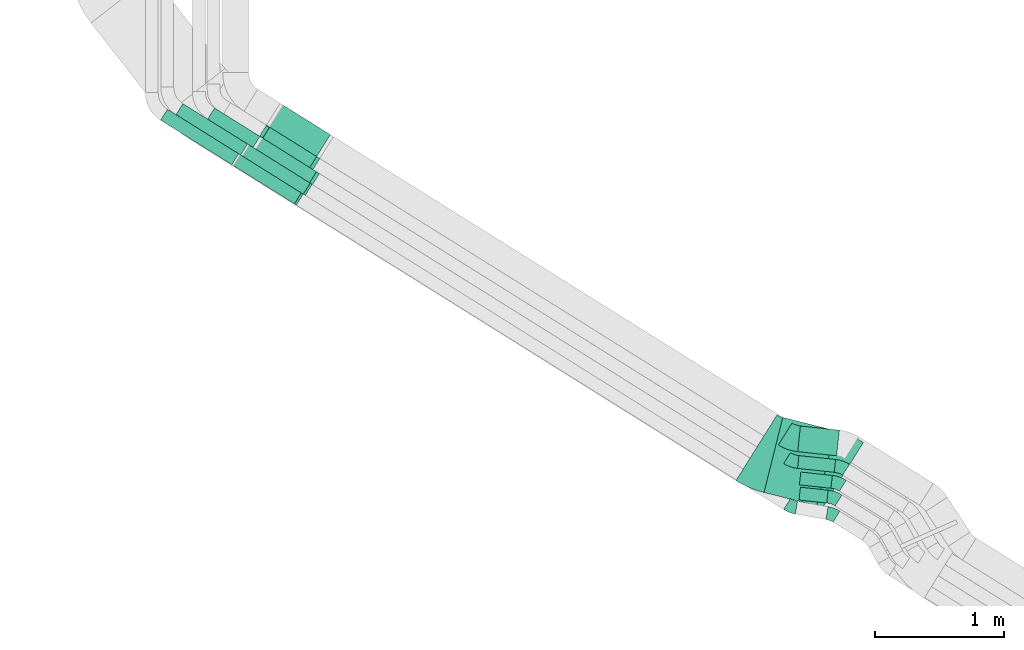
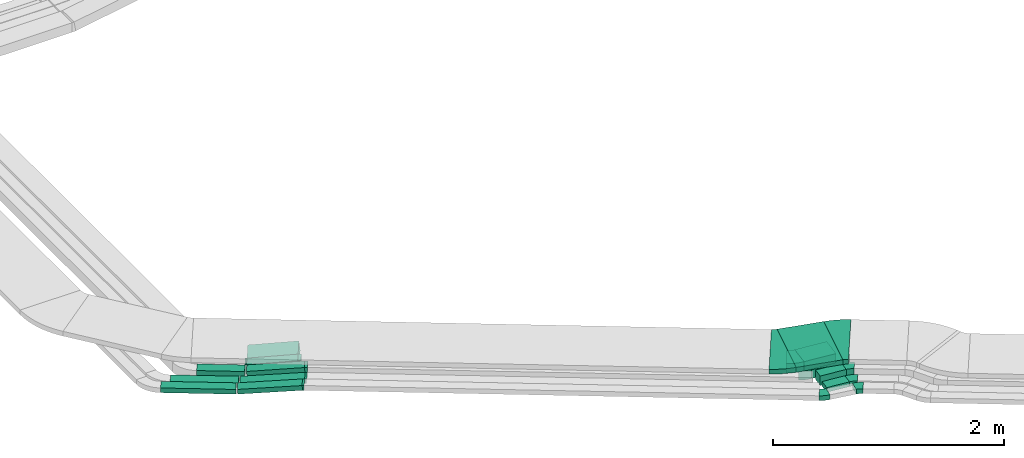
# One storey, part 8 of 38: 14 flow fittings, 13 flow segments.
"""IFC2X3 building model written with IfcOpenShell, lengths in millimetres."""

from ifc_helpers import new_model, entity, si_unit, converted_unit, derived_unit, direction, frame, frame_2d, origin, origin_2d_with_axis, place, context, subcontext, project, spatial, polyline, circle_curve, parameter, trimmed, segment, composite_curve, rectangle, outline, extrude, faceted_brep, source, transform, mapped, material, type_object, type_shapes, element, save


model = new_model("IFC2X3")

# Units and contexts
model_context = context("Model", 3, precision=0.01, world=origin(), true_north=direction((6.12303176911189e-17, 1.0)))
body_context = subcontext(model_context, "Body", "Model", "MODEL_VIEW")
ifc_project = project(units=[si_unit("LENGTHUNIT", "METRE", prefix="MILLI"), si_unit("AREAUNIT", "SQUARE_METRE"), si_unit("VOLUMEUNIT", "CUBIC_METRE"), converted_unit("PLANEANGLEUNIT", "DEGREE", entity("IfcRatioMeasure", 0.0174532925199433), si_unit("PLANEANGLEUNIT", "RADIAN"), dimensions=[0, 0, 0, 0, 0, 0, 0]), si_unit("MASSUNIT", "GRAM", prefix="KILO"), derived_unit("MASSDENSITYUNIT", [(si_unit("MASSUNIT", "GRAM", prefix="KILO"), 1), (si_unit("LENGTHUNIT", "METRE"), -3)]), derived_unit("MOMENTOFINERTIAUNIT", [(si_unit("LENGTHUNIT", "METRE"), 4)]), si_unit("TIMEUNIT", "SECOND"), si_unit("FREQUENCYUNIT", "HERTZ"), si_unit("THERMODYNAMICTEMPERATUREUNIT", "DEGREE_CELSIUS"), derived_unit("THERMALTRANSMITTANCEUNIT", [(si_unit("MASSUNIT", "GRAM", prefix="KILO"), 1), (si_unit("THERMODYNAMICTEMPERATUREUNIT", "KELVIN"), -1), (si_unit("TIMEUNIT", "SECOND"), -3)]), derived_unit("VOLUMETRICFLOWRATEUNIT", [(si_unit("LENGTHUNIT", "METRE"), 3), (si_unit("TIMEUNIT", "SECOND"), -1)]), derived_unit("MASSFLOWRATEUNIT", [(si_unit("MASSUNIT", "GRAM", prefix="KILO"), 1), (si_unit("TIMEUNIT", "SECOND"), -1)]), derived_unit("ROTATIONALFREQUENCYUNIT", [(si_unit("TIMEUNIT", "SECOND"), -1)]), si_unit("ELECTRICCURRENTUNIT", "AMPERE"), si_unit("ELECTRICVOLTAGEUNIT", "VOLT"), si_unit("POWERUNIT", "WATT"), si_unit("FORCEUNIT", "NEWTON", prefix="KILO"), si_unit("ILLUMINANCEUNIT", "LUX"), si_unit("LUMINOUSFLUXUNIT", "LUMEN"), si_unit("LUMINOUSINTENSITYUNIT", "CANDELA"), derived_unit("USERDEFINED", [(si_unit("MASSUNIT", "GRAM", prefix="KILO"), -1), (si_unit("LENGTHUNIT", "METRE"), -2), (si_unit("TIMEUNIT", "SECOND"), 3), (si_unit("LUMINOUSFLUXUNIT", "LUMEN"), 1)]), derived_unit("LINEARVELOCITYUNIT", [(si_unit("LENGTHUNIT", "METRE"), 1), (si_unit("TIMEUNIT", "SECOND"), -1)]), si_unit("PRESSUREUNIT", "PASCAL"), derived_unit("USERDEFINED", [(si_unit("LENGTHUNIT", "METRE"), -2), (si_unit("MASSUNIT", "GRAM", prefix="KILO"), 1), (si_unit("TIMEUNIT", "SECOND"), -2)]), derived_unit("LINEARFORCEUNIT", [(si_unit("MASSUNIT", "GRAM", prefix="KILO"), 1), (si_unit("LENGTHUNIT", "METRE"), 1), (si_unit("TIMEUNIT", "SECOND"), -2), (si_unit("LENGTHUNIT", "METRE"), -1)]), derived_unit("PLANARFORCEUNIT", [(si_unit("MASSUNIT", "GRAM", prefix="KILO"), 1), (si_unit("LENGTHUNIT", "METRE"), 1), (si_unit("TIMEUNIT", "SECOND"), -2), (si_unit("LENGTHUNIT", "METRE"), -2)])], contexts=[model_context])

# Site, building, storey
site_placement = place(None, frame((0.0, -0.00077364408347762, 0.0)))
site = spatial("IfcSite", under=ifc_project, at=site_placement, CompositionType="ELEMENT")
building_placement = place(site_placement, origin())
building = spatial("IfcBuilding", under=site, at=building_placement, CompositionType="ELEMENT")
storey_placement = place(building_placement, frame((0.0, 0.0, 4200.0)))
storey = spatial("IfcBuildingStorey", under=building, at=storey_placement, CompositionType="ELEMENT", Elevation=4200.0)

# Flow segments
cable_carrier_segment_type = type_object("IfcCableCarrierSegmentType", PredefinedType="CABLETRAYSEGMENT")
flow_segment_1_placement = place(storey_placement, frame((11021.9593826731, 6012.63176187368, 2780.0)))
element("IfcFlowSegment", 1, at=flow_segment_1_placement, inside=storey, type_object=cable_carrier_segment_type, context=body_context, shape_type="SweptSolid", body=[
    extrude(rectangle(XDim=590.779348946736, YDim=99.9999999999992, at=frame_2d((2.8421709430404e-13, -4.58300064565265e-13), x_axis=(1.0, 0.0))), frame((277.000614273059, 198.935083766848, 0.0), z_axis=(0.0, 0.0, 1.0), x_axis=(-0.848048096156395, 0.529919264233255, 0.0)), (0.0, 0.0, 1.0), 49.9999999999995),
])
flow_segment_2_placement = place(storey_placement, frame((10901.9593826731, 5937.63443186581, 2780.0)))
element("IfcFlowSegment", 2, at=flow_segment_2_placement, inside=storey, type_object=cable_carrier_segment_type, context=body_context, shape_type="SweptSolid", body=[
    extrude(rectangle(XDim=650.976943556377, YDim=99.9999999999992, at=frame_2d((-9.09494701772928e-13, -5.75539615965681e-13), x_axis=(1.0, 0.0))), frame((302.525842024012, 214.885016288922, 0.0), z_axis=(0.0, 0.0, 1.0), x_axis=(-0.848048096156398, 0.529919264233251, 0.0)), (0.0, 0.0, 1.0), 49.9999999999994),
])
flow_segment_3_placement = place(storey_placement, frame((15850.3279438837, 3315.85670143995, 2836.0)))
element("IfcFlowSegment", 3, at=flow_segment_3_placement, inside=storey, type_object=cable_carrier_segment_type, context=body_context, shape_type="SweptSolid", body=[
    extrude(rectangle(XDim=215.79362758406, YDim=99.9999999999994, at=frame_2d((1.03739239420975e-12, 3.90798504668055e-13), x_axis=(1.0, 0.0))), frame((112.591841789923, 61.1631080008714, 0.0), z_axis=(0.0, 0.0, 1.0), x_axis=(0.994358083083249, -0.106075457137867, 0.0)), (0.0, 0.0, 1.0), 49.9999999999994),
])
flow_segment_4_placement = place(storey_placement, frame((15852.9769620109, 3430.11873830787, 2836.0)))
element("IfcFlowSegment", 4, at=flow_segment_4_placement, inside=storey, type_object=cable_carrier_segment_type, context=body_context, shape_type="SweptSolid", body=[
    extrude(rectangle(XDim=245.980376559461, YDim=99.9999999999996, at=frame_2d((-3.5527136788005e-14, 2.66453525910038e-13), x_axis=(1.0, 0.0))), frame((127.60006071277, 62.7641445993965, 0.0), z_axis=(0.0, 0.0, 1.0), x_axis=(0.994358083083258, -0.106075457137776, 0.0)), (0.0, 0.0, 1.0), 99.9999999999989),
])
flow_segment_5_placement = place(storey_placement, frame((15838.5294447758, 3553.72125251607, 2836.0)))
element("IfcFlowSegment", 5, at=flow_segment_5_placement, inside=storey, type_object=cable_carrier_segment_type, context=body_context, shape_type="SweptSolid", body=[
    extrude(rectangle(XDim=285.980376559459, YDim=99.9999999999996, at=origin_2d_with_axis()), frame((147.487222374434, 64.8856537421533, 0.0), z_axis=(0.0, 0.0, 1.0), x_axis=(0.994358083083257, -0.106075457137787, 0.0)), (0.0, 0.0, 1.0), 99.9999999999989),
])
flow_segment_6_placement = place(storey_placement, frame((15839.5849562289, 3681.4986497442, 2836.0)))
element("IfcFlowSegment", 6, at=flow_segment_6_placement, inside=storey, type_object=cable_carrier_segment_type, context=body_context, shape_type="SweptSolid", body=[
    extrude(rectangle(XDim=303.568110682782, YDim=200.0, at=frame_2d((2.17426077142591e-12, -3.5527136788005e-14), x_axis=(1.0, 0.0))), frame((161.535248025646, 115.536371364891, 0.0), z_axis=(0.0, 0.0, 1.0), x_axis=(0.994358083083256, -0.106075457137793, 0.0)), (0.0, 0.0, 1.0), 99.9999999999989),
])
flow_segment_7_placement = place(storey_placement, frame((15578.6070161036, 3295.27526726807, 3108.85255784634)))
element("IfcFlowSegment", 7, at=flow_segment_7_placement, inside=storey, type_object=cable_carrier_segment_type, context=body_context, shape_type="SweptSolid", body=[
    extrude(rectangle(XDim=419.986776604596, YDim=600.000000000001, at=frame_2d((-1.03739239420975e-12, -2.55795384873636e-13), x_axis=(1.0, 0.0))), frame((276.332255895841, 341.89071644429, 0.0), z_axis=(0.0, 0.0, 1.0), x_axis=(0.970295726275994, -0.241921895599679, 0.0)), (0.0, 0.0, 1.0), 49.9999999999995),
])
flow_segment_8_placement = place(storey_placement, frame((11464.9459833345, 5631.65560913535, 2780.8615018426)))
element("IfcFlowSegment", 8, at=flow_segment_8_placement, inside=storey, type_object=cable_carrier_segment_type, context=body_context, shape_type="SweptSolid", body=[
    extrude(rectangle(XDim=50.0000000000007, YDim=100.0, at=frame_2d((0.0, 0.0), x_axis=(0.0, 1.0))), frame((28.5512409538923, 340.269098140738, 24.8822518695974), z_axis=(0.844053853043885, -0.527423384128046, 0.0969415650621141), x_axis=(0.529919264233164, 0.848048096156452, 0.0)), (0.0, 0.0, 1.0), 562.323215441914),
])
flow_segment_9_placement = place(storey_placement, frame((11533.8955278326, 5706.6529391432, 2780.8615018426)))
element("IfcFlowSegment", 9, at=flow_segment_9_placement, inside=storey, type_object=cable_carrier_segment_type, context=body_context, shape_type="SweptSolid", body=[
    extrude(rectangle(XDim=50.0000000000008, YDim=99.9999999999974, at=origin_2d_with_axis()), frame((28.5512409538923, 340.269098140755, 24.8822518695974), z_axis=(0.844053853043877, -0.527423384128054, 0.0969415650621368), x_axis=(-0.0822111096893616, 0.0513712028313554, 0.995290074783881)), (0.0, 0.0, 1.0), 562.323215441913),
])
flow_segment_10_placement = place(storey_placement, frame((11632.318333467, 5792.32698271948, 2781.41755828794)))
element("IfcFlowSegment", 10, at=flow_segment_10_placement, inside=storey, type_object=cable_carrier_segment_type, context=body_context, shape_type="SweptSolid", body=[
    extrude(rectangle(XDim=100.0, YDim=100.000000000001, at=origin_2d_with_axis()), frame((31.0187386409068, 310.671196419434, 49.7147605235467), z_axis=(0.843210160257302, -0.526896186363397, 0.106663182188436), x_axis=(-0.0904555085848854, 0.0565228750260753, 0.994295210470933)), (0.0, 0.0, 1.0), 503.785479436427),
])
flow_segment_11_placement = place(storey_placement, frame((11266.9593826731, 6071.81475346182, 2780.0)))
element("IfcFlowSegment", 11, at=flow_segment_11_placement, inside=storey, type_object=cable_carrier_segment_type, context=body_context, shape_type="SweptSolid", body=[
    extrude(rectangle(XDim=414.985433178406, YDim=99.9999999999999, at=frame_2d((-9.2370555648813e-13, -5.6843418860808e-13), x_axis=(1.0, 0.0))), frame((202.459766481463, 152.356792516509, 0.0), z_axis=(0.0, 0.0, 1.0), x_axis=(-0.848048096156469, 0.529919264233136, 0.0)), (0.0, 0.0, 1.0), 100.000000000002),
])
flow_segment_12_placement = place(storey_placement, frame((11683.602561029, 5909.58392938224, 2781.71258128786)))
element("IfcFlowSegment", 12, at=flow_segment_12_placement, inside=storey, type_object=cable_carrier_segment_type, context=body_context, shape_type="SweptSolid", body=[
    extrude(rectangle(XDim=100.0, YDim=100.0, at=frame_2d((0.0, 0.0), x_axis=(0.0, 1.0))), frame((31.5709009124962, 279.841000198346, 49.6405949695712), z_axis=(0.841952241120385, -0.526110151247443, 0.119685138704662), x_axis=(0.529919264233164, 0.848048096156452, 0.0)), (0.0, 0.0, 1.0), 445.282079813443),
])
flow_segment_13_placement = place(storey_placement, frame((11736.8331346971, 5994.77065442334, 2781.71258128782)))
element("IfcFlowSegment", 13, at=flow_segment_13_placement, inside=storey, type_object=cable_carrier_segment_type, context=body_context, shape_type="SweptSolid", body=[
    extrude(rectangle(XDim=99.9999999999993, YDim=200.0, at=frame_2d((0.0, 0.0), x_axis=(0.0, 1.0))), frame((58.0668641241479, 322.243405005858, 49.6405949696156), z_axis=(0.841952241120382, -0.526110151247425, 0.119685138704764), x_axis=(0.529919264233197, 0.848048096156431, 0.0)), (0.0, 0.0, 1.0), 445.282079812818),
])

# Flow fittings
ifc_material = material()
cable_carrier_fitting_type_1 = type_object("IfcCableCarrierFittingType", Name="470_DKC_S5_Variable Angle Elbow 0-45:-", PredefinedType="NOTDEFINED", material=ifc_material)
shared_shape_1 = source(origin(), body_context, "Body", "SweptSolid", [
    extrude(outline(composite_curve([segment(polyline([(-38.442455305234, -57.3752661916753), (-37.4424553052327, -57.3752661916753)]), True, "CONTINUOUS"), segment(trimmed(circle_curve(frame_2d((-37.4424553052331, 192.624733808324), x_axis=(0.0, -1.0)), 250.0), [parameter(0.0)], [parameter(22.0)], True, "PARAMETER"), True, "CONTINUOUS"), segment(polyline([(56.2091930487454, -39.1712298333719), (57.1363769033121, -38.7966232399561)]), True, "CONTINUOUS"), segment(polyline([(57.1363769033121, -38.7966232399561), (19.6757175617208, 53.9217622167225)]), True, "CONTINUOUS"), segment(polyline([(19.6757175617208, 53.9217622167225), (18.748533707154, 53.5471556233066)]), True, "CONTINUOUS"), segment(trimmed(circle_curve(frame_2d((-37.4424553052331, 192.624733808324), x_axis=(0.0, -1.0)), 150.0), [parameter(0.0)], [parameter(22.0)], True, "PARAMETER"), False, "CONTINUOUS"), segment(polyline([(-37.4424553052327, 42.6247338083246), (-38.442455305234, 42.6247338083246)]), True, "CONTINUOUS"), segment(polyline([(-38.442455305234, 42.6247338083246), (-38.442455305234, -57.3752661916753)]), True, "CONTINUOUS")], self_intersect=False)), frame((-1.43360652230106, 7.37526619166724, -25.0)), (0.0, 0.0, 1.0), 50.0000000000001),
])
type_shapes(cable_carrier_fitting_type_1, [shared_shape_1])
for number, where, z_axis, x_axis, name in (
    (14, (15790.8204717438, 3286.65911469382, 2861.0), (0.0, 0.0, 1.0), (0.848048096156424, -0.529919264233208, 0.0), "470_DKC_S5_Variable Angle Elbow 0-45:-"),
    (15, (16105.9589527077, 3231.09169784038, 2861.0), (0.0, 0.0, 1.0), (-0.848048096156422, 0.529919264233211, 0.0), "470_DKC_S5_Variable Angle Elbow 0-45:-"),
):
    element("IfcFlowFitting", number, at=place(storey_placement, frame(where, z_axis=z_axis, x_axis=x_axis)), inside=storey, type_object=cable_carrier_fitting_type_1, material=ifc_material, Name=name, ObjectType="470_DKC_S5_Variable Angle Elbow 0-45:-", context=body_context, shape_type="MappedRepresentation", body=[
        mapped(shared_shape_1, transform((0.0, 0.0, 0.0), scale=1.0)),
    ])
cable_carrier_fitting_type_2 = type_object("IfcCableCarrierFittingType", Name="470_DKC_S5_Variable Angle Elbow 0-45:-", PredefinedType="NOTDEFINED", material=ifc_material)
shared_shape_2 = source(origin(), body_context, "Body", "SweptSolid", [
    extrude(outline(composite_curve([segment(polyline([(-44.6721101565691, -60.1617523579501), (-43.6721101565678, -60.1617523579501)]), True, "CONTINUOUS"), segment(trimmed(circle_curve(frame_2d((-43.6721101565682, 189.83824764205), x_axis=(0.0, -1.0)), 250.0), [parameter(0.0)], [parameter(25.9108682245421)], True, "PARAMETER"), True, "CONTINUOUS"), segment(polyline([(65.5709934176921, -35.0304792220105), (66.4704683251479, -34.5935068077137)]), True, "CONTINUOUS"), segment(polyline([(66.4704683251479, -34.5935068077137), (22.7732268954447, 55.3539839379108)]), True, "CONTINUOUS"), segment(polyline([(22.7732268954447, 55.3539839379108), (21.873751987988, 54.9170115236135)]), True, "CONTINUOUS"), segment(trimmed(circle_curve(frame_2d((-43.6721101565682, 189.83824764205), x_axis=(0.0, -1.0)), 150.0), [parameter(0.0)], [parameter(25.9108682245421)], True, "PARAMETER"), False, "CONTINUOUS"), segment(polyline([(-43.6721101565678, 39.8382476420498), (-44.6721101565691, 39.8382476420498)]), True, "CONTINUOUS"), segment(polyline([(-44.6721101565691, 39.8382476420498), (-44.6721101565691, -60.1617523579501)]), True, "CONTINUOUS")], self_intersect=False)), frame((-2.3377015636759, 10.161752357942, -25.0)), (0.0, 0.0, 1.0), 50.0),
])
type_shapes(cable_carrier_fitting_type_2, [shared_shape_2])
flow_fitting_1_placement = place(storey_placement, frame((16116.9524408749, 3360.5880183259, 2861.0), z_axis=(0.0, 0.0, 1.0), x_axis=(-0.848048096156432, 0.529919264233196, 0.0)))
element("IfcFlowFitting", 16, at=flow_fitting_1_placement, inside=storey, type_object=cable_carrier_fitting_type_2, material=ifc_material, Name="470_DKC_S5_Variable Angle Elbow 0-45:-", ObjectType="470_DKC_S5_Variable Angle Elbow 0-45:-", context=body_context, shape_type="MappedRepresentation", body=[
    mapped(shared_shape_2, transform((0.0, 0.0, 0.0), scale=1.0)),
])
cable_carrier_fitting_type_3 = type_object("IfcCableCarrierFittingType", Name="470_DKC_S5_Variable Angle Elbow 0-45:-", PredefinedType="NOTDEFINED", material=ifc_material)
shared_shape_3 = source(origin(), body_context, "Body", "SweptSolid", [
    extrude(outline(composite_curve([segment(polyline([(-44.6721101565771, -60.1617523579546), (-43.6721101565758, -60.1617523579546)]), True, "CONTINUOUS"), segment(trimmed(circle_curve(frame_2d((-43.6721101565784, 189.838247642045), x_axis=(0.0, -1.0)), 250.0), [parameter(0.0)], [parameter(25.9108682245476)], True, "PARAMETER"), True, "CONTINUOUS"), segment(polyline([(65.5709934177052, -35.0304792220038), (66.4704683251609, -34.5935068077069)]), True, "CONTINUOUS"), segment(polyline([(66.4704683251609, -34.5935068077069), (22.7732268954485, 55.3539839379131)]), True, "CONTINUOUS"), segment(polyline([(22.7732268954485, 55.3539839379132), (21.8737519879918, 54.9170115236158)]), True, "CONTINUOUS"), segment(trimmed(circle_curve(frame_2d((-43.6721101565784, 189.838247642045), x_axis=(0.0, -1.0)), 150.0), [parameter(0.0)], [parameter(25.9108682245476)], True, "PARAMETER"), False, "CONTINUOUS"), segment(polyline([(-43.6721101565766, 39.8382476420453), (-44.6721101565779, 39.8382476420453)]), True, "CONTINUOUS"), segment(polyline([(-44.6721101565779, 39.8382476420453), (-44.6721101565771, -60.1617523579546)]), True, "CONTINUOUS")], self_intersect=False)), frame((-2.33770156367735, 10.1617523579462, -50.0)), (0.0, 0.0, 1.0), 100.0),
])
type_shapes(cable_carrier_fitting_type_3, [shared_shape_3])
for number, where, z_axis, x_axis, name in (
    (17, (16149.6178968478, 3474.85005519382, 2886.0), (0.0, 0.0, 1.0), (-0.848048096156424, 0.529919264233209, 0.0), "470_DKC_S5_Variable Angle Elbow 0-45:-"),
    (18, (15797.0886313644, 3638.76124311443, 2886.0), (0.0, 0.0, 1.0), (0.848048096156421, -0.529919264233214, 0.0), "470_DKC_S5_Variable Angle Elbow 0-45:-"),
    (19, (16174.944702936, 3598.45256940201, 2886.0), (0.0, 0.0, 1.0), (-0.848048096156423, 0.529919264233211, 0.0), "470_DKC_S5_Variable Angle Elbow 0-45:-"),
):
    element("IfcFlowFitting", number, at=place(storey_placement, frame(where, z_axis=z_axis, x_axis=x_axis)), inside=storey, type_object=cable_carrier_fitting_type_3, material=ifc_material, Name=name, ObjectType="470_DKC_S5_Variable Angle Elbow 0-45:-", context=body_context, shape_type="MappedRepresentation", body=[
        mapped(shared_shape_3, transform((0.0, 0.0, 0.0), scale=1.0)),
    ])
cable_carrier_fitting_type_4 = type_object("IfcCableCarrierFittingType", Name="470_DKC_S5_Variable Angle Elbow 0-45:-", PredefinedType="NOTDEFINED", material=ifc_material)
shared_shape_4 = source(origin(), body_context, "Body", "SweptSolid", [
    extrude(outline(composite_curve([segment(polyline([(-55.5964205140059, -112.674879671549), (-54.5964205140047, -112.674879671549)]), True, "CONTINUOUS"), segment(trimmed(circle_curve(frame_2d((-54.5964205140051, 237.32512032845), x_axis=(0.0, -1.0)), 350.0), [parameter(0.0)], [parameter(25.9108682245477)], True, "PARAMETER"), True, "CONTINUOUS"), segment(polyline([(98.3439244899898, -77.4910972812192), (99.2433993974448, -77.0541248669227)]), True, "CONTINUOUS"), segment(polyline([(99.2433993974448, -77.0541248669226), (11.8489165380215, 102.840856624318)]), True, "CONTINUOUS"), segment(polyline([(11.8489165380215, 102.840856624318), (10.9494416305641, 102.403884210021)]), True, "CONTINUOUS"), segment(trimmed(circle_curve(frame_2d((-54.5964205140051, 237.32512032845), x_axis=(0.0, -1.0)), 150.0), [parameter(0.0)], [parameter(25.9108682245477)], True, "PARAMETER"), False, "CONTINUOUS"), segment(polyline([(-54.5964205140047, 87.3251203284505), (-55.5964205140059, 87.3251203284505)]), True, "CONTINUOUS"), segment(polyline([(-55.5964205140059, 87.3251203284505), (-55.5964205140059, -112.674879671549)]), True, "CONTINUOUS")], self_intersect=False)), frame((-2.91584413631518, 12.6748796715413, -50.0)), (0.0, 0.0, 1.0), 100.0),
])
type_shapes(cable_carrier_fitting_type_4, [shared_shape_4])
flow_fitting_2_placement = place(storey_placement, frame((15792.0103586281, 3819.34229938662, 2886.0), z_axis=(0.0, 0.0, 1.0), x_axis=(0.848048096156422, -0.529919264233211, 0.0)))
element("IfcFlowFitting", 20, at=flow_fitting_2_placement, inside=storey, type_object=cable_carrier_fitting_type_4, material=ifc_material, Name="470_DKC_S5_Variable Angle Elbow 0-45:-", ObjectType="470_DKC_S5_Variable Angle Elbow 0-45:-", context=body_context, shape_type="MappedRepresentation", body=[
    mapped(shared_shape_4, transform((0.0, 0.0, 0.0), scale=1.0)),
])
cable_carrier_fitting_type_5 = type_object("IfcCableCarrierFittingType", Name="470_DKC_S5_Variable Angle Elbow 0-45:-", PredefinedType="NOTDEFINED", material=ifc_material)
shared_shape_5 = source(origin(), body_context, "Body", "SweptSolid", [
    extrude(outline(composite_curve([segment(polyline([(-70.5165878634466, -311.089538082181), (-69.5165878634449, -311.089538082181)]), True, "CONTINUOUS"), segment(trimmed(circle_curve(frame_2d((-69.5165878634204, 438.910461917818), x_axis=(0.0, -1.0)), 750.0), [parameter(0.0)], [parameter(17.9999999999994)], True, "PARAMETER"), True, "CONTINUOUS"), segment(polyline([(162.24615791776, -274.381925303556), (163.197214434056, -274.072908309181)]), True, "CONTINUOUS"), segment(polyline([(163.197214434056, -274.072908309181), (-22.2129821908907, 296.561001467918)]), True, "CONTINUOUS"), segment(polyline([(-22.2129821908907, 296.561001467918), (-23.1640387071844, 296.251984473544)]), True, "CONTINUOUS"), segment(trimmed(circle_curve(frame_2d((-69.5165878634204, 438.910461917818), x_axis=(0.0, -1.0)), 150.0), [parameter(0.0)], [parameter(17.9999999999994)], True, "PARAMETER"), False, "CONTINUOUS"), segment(polyline([(-69.5165878634246, 288.910461917819), (-70.5165878634263, 288.910461917819)]), True, "CONTINUOUS"), segment(polyline([(-70.5165878634263, 288.910461917819), (-70.5165878634466, -311.089538082181)]), True, "CONTINUOUS")], self_intersect=False)), frame((-1.75641028259411, 11.0895380821755, -25.0)), (0.0, 0.0, 1.0), 50.0000000000027),
])
type_shapes(cable_carrier_fitting_type_5, [shared_shape_5])
for number, where, z_axis, x_axis, name in (
    (21, (15581.0574035572, 3705.45240298603, 3133.85255784634), (0.0, 0.0, 1.0), (0.84804809615643, -0.529919264233199, 0.0), "470_DKC_S5_Variable Angle Elbow 0-45:-"),
    (22, (16128.8211404416, 3568.87956443868, 3133.85255784634), (0.0, 0.0, 1.0), (-0.848048096156421, 0.529919264233213, 0.0), "470_DKC_S5_Variable Angle Elbow 0-45:-"),
):
    element("IfcFlowFitting", number, at=place(storey_placement, frame(where, z_axis=z_axis, x_axis=x_axis)), inside=storey, type_object=cable_carrier_fitting_type_5, material=ifc_material, Name=name, ObjectType="470_DKC_S5_Variable Angle Elbow 0-45:-", context=body_context, shape_type="MappedRepresentation", body=[
        mapped(shared_shape_5, transform((0.0, 0.0, 0.0), scale=1.0)),
    ])
cable_carrier_fitting_type_6 = type_object("IfcCableCarrierFittingType", PredefinedType="NOTDEFINED", material=ifc_material)
shared_shape_6 = source(origin(), body_context, "Body", "Brep", [
    faceted_brep([(-7.67218593717382, -25.0, 50.0), (-7.67218593717366, 25.0, 50.0), (-7.67218593717366, 25.0, 47.4600000101635), (-7.67218593717382, -22.46000001016, 47.4600000101635), (-7.67218593717382, -22.46000001016, -47.4600000101565), (-7.67218593717366, 25.0, -47.4600000101565), (-7.67218593717366, 25.0, -50.0), (-7.67218593717382, -25.0, -50.0), (10.059589641721, -24.1384981573996, 50.0), (10.059589641721, -24.1384981573996, -50.0), (5.21251138861143, 25.6260055817942, -50.0), (5.21251138861142, 25.6260055817942, -47.4600000101565), (9.813358067448, -21.6104613775607, -47.4600000101565), (9.813358067448, -21.6104613775607, 47.4600000101635), (5.21251138861143, 25.6260055817942, 47.4600000101635), (5.21251138861143, 25.6260055817942, 50.0), (1.21462997144311, -25.0, 50.0), (-1.21462997144238, 25.0, 50.0), (-1.21462997144238, 25.0, 47.4600000101635), (1.09122356683813, -22.46000001016, 47.4600000101635), (1.09122356683813, -22.46000001016, -47.4600000101565), (-1.21462997144238, 25.0, -47.4600000101565), (-1.21462997144238, 25.0, -50.0), (1.21462997144309, -25.0, -50.0)], [[[0, 1, 2, 3, 4, 5, 6, 7]], [[8, 9, 10, 11, 12, 13, 14, 15]], [[1, 0, 16, 8, 15, 17]], [[2, 1, 17, 18]], [[3, 2, 18, 14, 13, 19]], [[4, 3, 19, 20]], [[5, 4, 20, 12, 11, 21]], [[6, 5, 21, 22]], [[7, 6, 22, 10, 9, 23]], [[0, 7, 23, 16]], [[18, 17, 15, 14]], [[20, 19, 13, 12]], [[22, 21, 11, 10]], [[16, 23, 9, 8]]]),
])
type_shapes(cable_carrier_fitting_type_6, [shared_shape_6])
for number, where, z_axis, x_axis in (
    (23, (11974.6040390398, 5671.29580374331, 2861.0), (-0.529919264233211, -0.848048096156423, 0.0), (-0.848048096156423, 0.529919264233211, 0.0)),
    (24, (12043.5535835378, 5746.29313375116, 2861.0), (-0.52991926423321, -0.848048096156423, 0.0), (-0.848048096156423, 0.52991926423321, 0.0)),
):
    element("IfcFlowFitting", number, at=place(storey_placement, frame(where, z_axis=z_axis, x_axis=x_axis)), inside=storey, type_object=cable_carrier_fitting_type_6, material=ifc_material, context=body_context, shape_type="MappedRepresentation", body=[
        mapped(shared_shape_6, transform((0.0, 0.0, 0.0), scale=1.0)),
    ])
cable_carrier_fitting_type_7 = type_object("IfcCableCarrierFittingType", PredefinedType="NOTDEFINED", material=ifc_material)
shared_shape_7 = source(origin(), body_context, "Body", "Brep", [
    faceted_brep([(-10.6158356450863, -50.0, 50.0), (-10.615835645086, 50.0, 50.0), (-10.615835645086, 50.0, 47.4600000101635), (-10.6158356450863, -47.46000001016, 47.4600000101635), (-10.6158356450863, -47.46000001016, -47.4600000101565), (-10.615835645086, 50.0, -47.4600000101565), (-10.615835645086, 50.0, -50.0), (-10.6158356450863, -50.0, -50.0), (15.8884336464794, -48.5824417120524, 50.0), (15.8884336464794, -48.5824417120524, -50.0), (5.22211542763368, 50.8470793350406, -50.0), (5.22211542763368, 50.8470793350406, -47.4600000101565), (15.6175091648045, -46.0569318875583, -47.4600000101564), (15.6175091648045, -46.0569318875583, 47.4600000101635), (5.22211542763368, 50.8470793350406, 47.4600000101635), (5.22211542763368, 50.8470793350407, 50.0), (2.67420745004155, -50.0, 50.0), (-2.67420745004082, 50.0, 50.0), (-2.67420745004081, 50.0, 47.4600000101635), (2.53835771212283, -47.46000001016, 47.4600000101635), (2.53835771212283, -47.46000001016, -47.4600000101565), (-2.67420745004082, 50.0, -47.4600000101565), (-2.67420745004082, 50.0, -50.0), (2.67420745004152, -50.0, -50.0)], [[[0, 1, 2, 3, 4, 5, 6, 7]], [[8, 9, 10, 11, 12, 13, 14, 15]], [[1, 0, 16, 8, 15, 17]], [[2, 1, 17, 18]], [[3, 2, 18, 14, 13, 19]], [[4, 3, 19, 20]], [[5, 4, 20, 12, 11, 21]], [[6, 5, 21, 22]], [[7, 6, 22, 10, 9, 23]], [[0, 7, 23, 16]], [[18, 17, 15, 14]], [[20, 19, 13, 12]], [[22, 21, 11, 10]], [[16, 23, 9, 8]]]),
])
type_shapes(cable_carrier_fitting_type_7, [shared_shape_7])
flow_fitting_3_placement = place(storey_placement, frame((12097.0854874344, 5831.96208796215, 2886.0), z_axis=(-0.52991926423321, -0.848048096156423, 0.0), x_axis=(-0.848048096156423, 0.52991926423321, 0.0)))
element("IfcFlowFitting", 25, at=flow_fitting_3_placement, inside=storey, type_object=cable_carrier_fitting_type_7, material=ifc_material, context=body_context, shape_type="MappedRepresentation", body=[
    mapped(shared_shape_7, transform((0.0, 0.0, 0.0), scale=1.0)),
])
cable_carrier_fitting_type_8 = type_object("IfcCableCarrierFittingType", PredefinedType="NOTDEFINED", material=ifc_material)
shared_shape_8 = source(origin(), body_context, "Body", "Brep", [
    faceted_brep([(-11.3061343460658, -50.0, 50.0), (-11.3061343460655, 50.0, 50.0), (-11.3061343460655, 50.0, 47.4600000101635), (-11.3061343460658, -47.46000001016, 47.4600000101635), (-11.3061343460658, -47.46000001016, -47.4600000101565), (-11.3061343460655, 50.0, -47.4600000101565), (-11.3061343460655, 50.0, -50.0), (-11.3061343460658, -50.0, -50.0), (17.2091216501317, -48.2874187121482, 50.0), (17.2091216501317, -48.2874187121482, -50.0), (5.24060777965415, 50.9937712269948, -50.0), (5.24060777965415, 50.9937712269948, -47.4600000101565), (16.9051213990376, -45.765676497781, -47.4600000101565), (16.9051213990376, -45.765676497781, 47.4600000101635), (5.24060777965415, 50.9937712269948, 47.4600000101635), (5.24060777965415, 50.9937712269948, 50.0), (3.00292111717459, -50.0, 50.0), (-3.00292111717387, 50.0, 50.0), (-3.00292111717387, 50.0, 47.4600000101635), (2.8503727250323, -47.46000001016, 47.4600000101635), (2.8503727250323, -47.46000001016, -47.4600000101565), (-3.00292111717387, 50.0, -47.4600000101565), (-3.00292111717387, 50.0, -50.0), (3.00292111717456, -50.0, -50.0)], [[[0, 1, 2, 3, 4, 5, 6, 7]], [[8, 9, 10, 11, 12, 13, 14, 15]], [[1, 0, 16, 8, 15, 17]], [[2, 1, 17, 18]], [[3, 2, 18, 14, 13, 19]], [[4, 3, 19, 20]], [[5, 4, 20, 12, 11, 21]], [[6, 5, 21, 22]], [[7, 6, 22, 10, 9, 23]], [[0, 7, 23, 16]], [[18, 17, 15, 14]], [[20, 19, 13, 12]], [[22, 21, 11, 10]], [[16, 23, 9, 8]]]),
])
type_shapes(cable_carrier_fitting_type_8, [shared_shape_8])
for number, where, z_axis, x_axis in (
    (26, (11705.6542367904, 6195.37320163142, 2830.0), (-0.529919264233235, -0.848048096156407, 0.0), (0.848048096156407, -0.529919264233235, 0.0)),
    (27, (12099.5989321222, 5949.20923517133, 2886.0), (-0.529919264233217, -0.848048096156419, 0.0), (-0.848048096156419, 0.529919264233217, 0.0)),
):
    element("IfcFlowFitting", number, at=place(storey_placement, frame(where, z_axis=z_axis, x_axis=x_axis)), inside=storey, type_object=cable_carrier_fitting_type_8, material=ifc_material, context=body_context, shape_type="MappedRepresentation", body=[
        mapped(shared_shape_8, transform((0.0, 0.0, 0.0), scale=1.0)),
    ])

save(model, "model.ifc")
